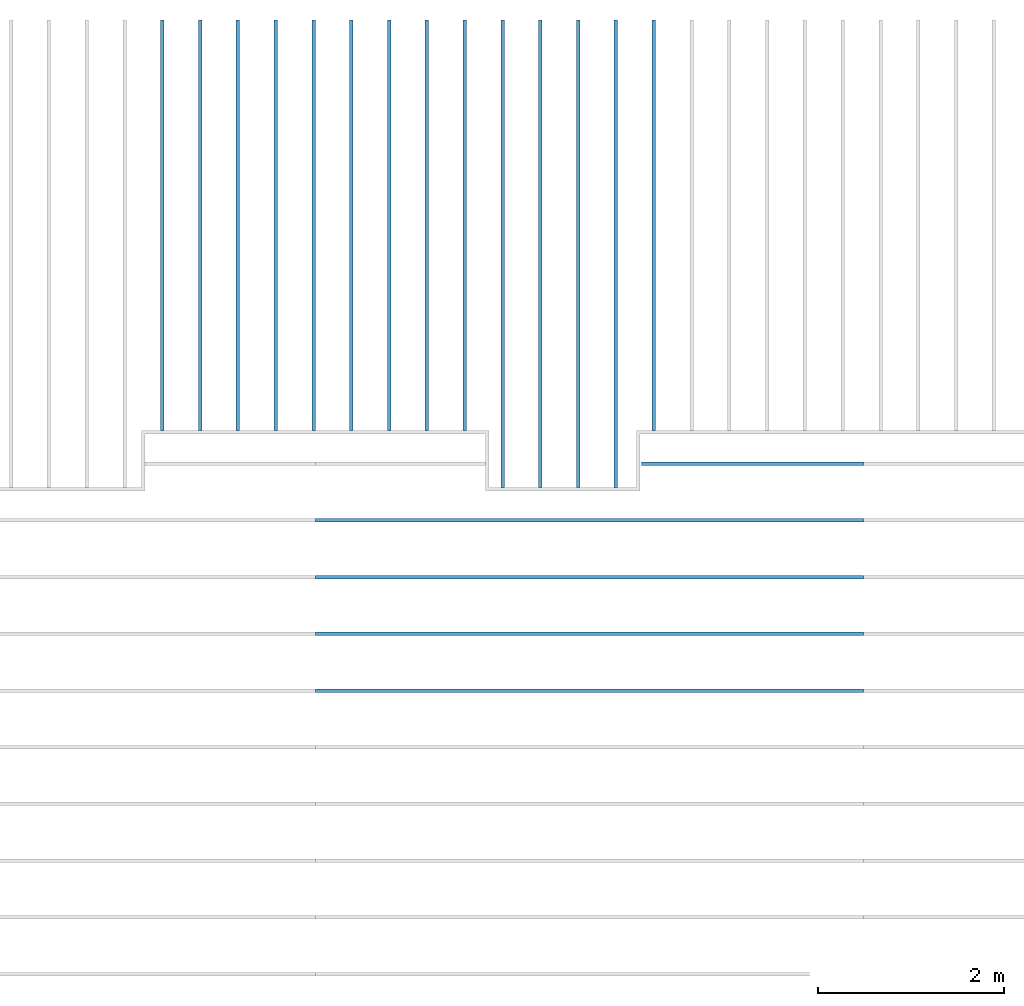
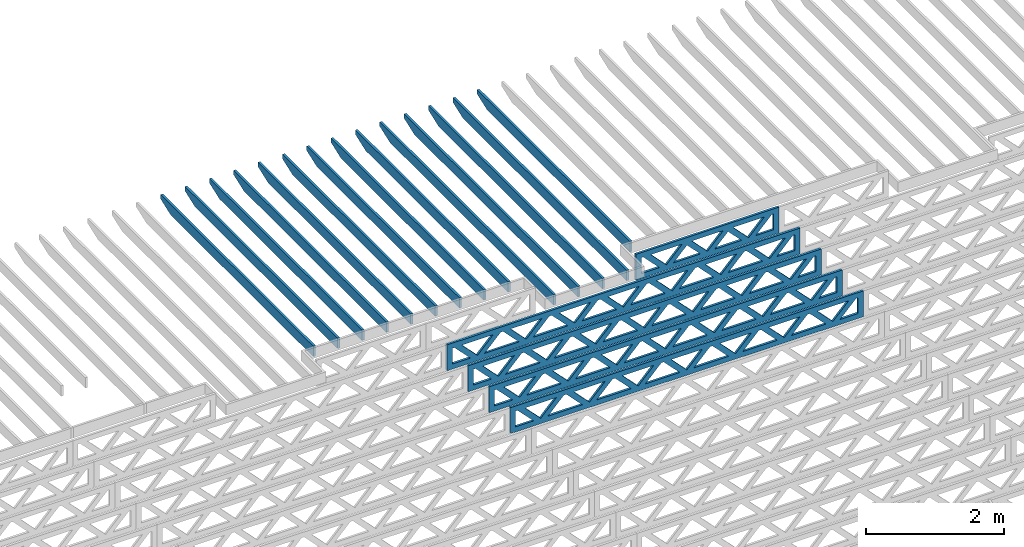
# One storey, part 10 of 17: 19 beams, 2 elements without a shape of their own.
"""IFC4 building model written with IfcOpenShell, lengths in feet."""

from ifc_helpers import new_model, entity, si_unit, converted_unit, derived_unit, direction, frame, frame_2d, origin, origin_2d_with_axis, place, context, subcontext, project, spatial, rectangle, extrude, clip, halfspace, source, transform, mapped, material, material_profile, profile_set, profile_usage, type_object, type_shapes, element, aggregate, save


model = new_model("IFC4")

# Units and contexts
model_context = context("Model", 3, precision=0.0001, world=origin(), true_north=direction((6.12303176911189e-17, 1.0)))
body_context = subcontext(model_context, "Body", "Model", "MODEL_VIEW")
ifc_project = project(units=[converted_unit("LENGTHUNIT", "FOOT", entity("IfcRatioMeasure", 0.3048), si_unit("LENGTHUNIT", "METRE"), dimensions=[1, 0, 0, 0, 0, 0, 0]), converted_unit("AREAUNIT", "SQUARE FOOT", entity("IfcRatioMeasure", 0.09290304), si_unit("AREAUNIT", "SQUARE_METRE"), dimensions=[2, 0, 0, 0, 0, 0, 0]), converted_unit("VOLUMEUNIT", "CUBIC FOOT", entity("IfcRatioMeasure", 0.028316846592), si_unit("VOLUMEUNIT", "CUBIC_METRE"), dimensions=[3, 0, 0, 0, 0, 0, 0]), converted_unit("PLANEANGLEUNIT", "DEGREE", entity("IfcRatioMeasure", 0.0174532925199433), si_unit("PLANEANGLEUNIT", "RADIAN"), dimensions=[0, 0, 0, 0, 0, 0, 0]), si_unit("MASSUNIT", "GRAM", prefix="KILO"), derived_unit("MASSDENSITYUNIT", [(si_unit("MASSUNIT", "GRAM", prefix="KILO"), 1), (si_unit("LENGTHUNIT", "METRE"), -3)]), derived_unit("MOMENTOFINERTIAUNIT", [(si_unit("LENGTHUNIT", "METRE"), 4)]), si_unit("TIMEUNIT", "SECOND"), si_unit("FREQUENCYUNIT", "HERTZ"), si_unit("THERMODYNAMICTEMPERATUREUNIT", "DEGREE_CELSIUS"), derived_unit("THERMALTRANSMITTANCEUNIT", [(si_unit("MASSUNIT", "GRAM", prefix="KILO"), 1), (si_unit("THERMODYNAMICTEMPERATUREUNIT", "KELVIN"), -1), (si_unit("TIMEUNIT", "SECOND"), -3)]), derived_unit("VOLUMETRICFLOWRATEUNIT", [(si_unit("LENGTHUNIT", "METRE"), 3), (si_unit("TIMEUNIT", "SECOND"), -1)]), si_unit("ELECTRICCURRENTUNIT", "AMPERE"), si_unit("ELECTRICVOLTAGEUNIT", "VOLT"), si_unit("POWERUNIT", "WATT"), si_unit("FORCEUNIT", "NEWTON"), si_unit("ILLUMINANCEUNIT", "LUX"), si_unit("LUMINOUSFLUXUNIT", "LUMEN"), si_unit("LUMINOUSINTENSITYUNIT", "CANDELA"), derived_unit("USERDEFINED", [(si_unit("MASSUNIT", "GRAM", prefix="KILO"), -1), (si_unit("LENGTHUNIT", "METRE"), -2), (si_unit("TIMEUNIT", "SECOND"), 3), (si_unit("LUMINOUSFLUXUNIT", "LUMEN"), 1)]), derived_unit("LINEARVELOCITYUNIT", [(si_unit("LENGTHUNIT", "METRE"), 1), (si_unit("TIMEUNIT", "SECOND"), -1)]), si_unit("PRESSUREUNIT", "PASCAL"), derived_unit("USERDEFINED", [(si_unit("LENGTHUNIT", "METRE"), -2), (si_unit("MASSUNIT", "GRAM", prefix="KILO"), 1), (si_unit("TIMEUNIT", "SECOND"), -2)]), derived_unit("LINEARFORCEUNIT", [(si_unit("MASSUNIT", "GRAM", prefix="KILO"), 1), (si_unit("LENGTHUNIT", "METRE"), 1), (si_unit("TIMEUNIT", "SECOND"), -2), (si_unit("LENGTHUNIT", "METRE"), -1)]), derived_unit("PLANARFORCEUNIT", [(si_unit("MASSUNIT", "GRAM", prefix="KILO"), 1), (si_unit("LENGTHUNIT", "METRE"), 1), (si_unit("TIMEUNIT", "SECOND"), -2), (si_unit("LENGTHUNIT", "METRE"), -2)])], contexts=[model_context])

# Site, building, storey
site_placement = place(None, origin())
site = spatial("IfcSite", under=ifc_project, at=site_placement, CompositionType="ELEMENT")
building_placement = place(site_placement, origin())
building = spatial("IfcBuilding", under=site, at=building_placement, CompositionType="ELEMENT")
storey_placement = place(building_placement, frame((0.0, 0.0, 30.4375000000082)))
storey = spatial("IfcBuildingStorey", under=building, at=storey_placement, Name="ROOF", CompositionType="ELEMENT", Elevation=30.4375000000082)

# Assembly, beams
assembly_1_placement = place(storey_placement, origin())
assembly_1 = element("IfcElementAssembly", 1, at=assembly_1_placement, inside=storey, Name="Structural Beam System:Structural Framing System", ObjectType="Structural Beam System:Structural Framing System", AssemblyPlace="NOTDEFINED", PredefinedType="BEAM_GRID")
ifc_material_1 = material(Name="WOOD TRUSS", Category="Materials")
ifc_material_profile_1 = material_profile(ifc_material_1, rectangle(XDim=1.73473973950632, YDim=0.125, at=origin_2d_with_axis()))
ifc_material_profile_2 = material_profile(ifc_material_1, rectangle(XDim=1.73473973950633, YDim=0.125, at=frame_2d((-1.11022302462516e-16, 0.0), x_axis=(1.0, 0.0))))
ifc_material_profile_3 = material_profile(ifc_material_1, rectangle(XDim=1.73473973950632, YDim=0.125, at=origin_2d_with_axis()))
ifc_material_profile_4 = material_profile(ifc_material_1, rectangle(XDim=1.73473973950633, YDim=0.125, at=origin_2d_with_axis()))
ifc_material_profile_5 = material_profile(ifc_material_1, rectangle(XDim=1.73473973950632, YDim=0.125, at=frame_2d((-5.55111512312578e-17, 0.0), x_axis=(1.0, 0.0))))
ifc_material_profile_6 = material_profile(ifc_material_1, rectangle(XDim=1.73473973950633, YDim=0.125, at=frame_2d((-2.77555756156289e-16, 0.0), x_axis=(1.0, 0.0))))
ifc_material_profile_7 = material_profile(ifc_material_1, rectangle(XDim=1.73473973950632, YDim=0.125, at=frame_2d((-4.9960036108132e-16, 0.0), x_axis=(1.0, 0.0))))
ifc_material_profile_8 = material_profile(ifc_material_1, rectangle(XDim=1.73473973950633, YDim=0.125, at=frame_2d((4.44089209850063e-16, 0.0), x_axis=(1.0, 0.0))))
ifc_material_profile_9 = material_profile(ifc_material_1, rectangle(XDim=1.73473973950632, YDim=0.125, at=origin_2d_with_axis()))
ifc_material_profile_10 = material_profile(ifc_material_1, rectangle(XDim=1.73473973950633, YDim=0.125, at=frame_2d((-4.9960036108132e-16, 0.0), x_axis=(1.0, 0.0))))
ifc_material_profile_11 = material_profile(ifc_material_1, rectangle(XDim=0.291666666666664, YDim=0.125, at=frame_2d((-2.77555756156289e-17, 0.0), x_axis=(1.0, 0.0))))
ifc_material_profile_12 = material_profile(ifc_material_1, rectangle(XDim=0.291666666666628, YDim=0.124999999999995, at=frame_2d((-5.55111512312578e-17, 0.0), x_axis=(1.0, 0.0))))
ifc_material_profile_13 = material_profile(ifc_material_1, rectangle(XDim=0.916666666666666, YDim=0.125000000000003, at=frame_2d((-2.77555756156289e-17, 0.0), x_axis=(1.0, 0.0))))
ifc_material_profile_14 = material_profile(ifc_material_1, rectangle(XDim=0.916666666666651, YDim=0.125, at=frame_2d((-2.77555756156289e-17, 0.0), x_axis=(1.0, 0.0))))
ifc_profile_set_1 = profile_set([ifc_material_profile_1, ifc_material_profile_2, ifc_material_profile_3, ifc_material_profile_4, ifc_material_profile_5, ifc_material_profile_6, ifc_material_profile_7, ifc_material_profile_8, ifc_material_profile_9, ifc_material_profile_10, ifc_material_profile_11, ifc_material_profile_12, ifc_material_profile_13, ifc_material_profile_14])
ifc_profile_usage_1 = profile_usage(ifc_profile_set_1, cardinal=8)
beam_type_1 = type_object("IfcBeamType", PredefinedType="BEAM", material=ifc_profile_set_1)
shared_shape_1 = source(origin(), body_context, "Body", "SweptSolid", [
    extrude(rectangle(XDim=1.73473973950632, YDim=0.125, at=origin_2d_with_axis()), frame((0.520059930714934, 0.0, 0.101118361020562), z_axis=(0.720569184836762, 0.0, -0.693383046997606), x_axis=(0.693383046997606, 0.0, 0.720569184836762)), (0.0, 0.0, 1.0), 0.291666666666667),
    extrude(rectangle(XDim=1.73473973950633, YDim=0.125, at=origin_2d_with_axis()), frame((-0.730225942958336, 0.0, -0.101118361020407), z_axis=(0.720569184836758, 0.0, 0.69338304699761), x_axis=(0.69338304699761, 0.0, -0.720569184836758)), (0.0, 0.0, 1.0), 0.291666666666666),
    extrude(rectangle(XDim=1.73473973950632, YDim=0.125, at=origin_2d_with_axis()), frame((2.77005983191593, 0.0, 0.101118361020514), z_axis=(0.720569184836762, 0.0, -0.693383046997606), x_axis=(0.693383046997606, 0.0, 0.720569184836762)), (0.0, 0.0, 1.0), 0.291666666666667),
    extrude(rectangle(XDim=1.73473973950633, YDim=0.125, at=frame_2d((-1.11022302462516e-16, 0.0), x_axis=(1.0, 0.0))), frame((1.51977395824266, 0.0, -0.101118361020455), z_axis=(0.720569184836758, 0.0, 0.69338304699761), x_axis=(0.69338304699761, 0.0, -0.720569184836758)), (0.0, 0.0, 1.0), 0.291666666666666),
    extrude(rectangle(XDim=1.73473973950632, YDim=0.125, at=frame_2d((-5.55111512312578e-17, 0.0), x_axis=(1.0, 0.0))), frame((-1.72993997048606, 0.0, 0.101118361020555), z_axis=(0.720569184836762, 0.0, -0.693383046997606), x_axis=(0.693383046997606, 0.0, 0.720569184836762)), (0.0, 0.0, 1.0), 0.291666666666667),
    extrude(rectangle(XDim=1.73473973950633, YDim=0.125, at=frame_2d((-2.77555756156289e-16, 0.0), x_axis=(1.0, 0.0))), frame((-2.98022584415933, 0.0, -0.101118361020414), z_axis=(0.720569184836758, 0.0, 0.69338304699761), x_axis=(0.69338304699761, 0.0, -0.720569184836758)), (0.0, 0.0, 1.0), 0.291666666666666),
    extrude(rectangle(XDim=0.291666666666664, YDim=0.125, at=frame_2d((-2.77555756156289e-17, 0.0), x_axis=(1.0, 0.0))), frame((-3.91666656786758, 0.0, 0.604166666666611), z_axis=(1.0, 0.0, 0.0), x_axis=(0.0, 0.0, -1.0)), (0.0, 0.0, 1.0), 7.83333313573516),
    extrude(rectangle(XDim=0.291666666666628, YDim=0.124999999999995, at=frame_2d((-5.55111512312578e-17, 0.0), x_axis=(1.0, 0.0))), frame((-3.91666656786737, 0.0, -0.604166666666693), z_axis=(1.0, 0.0, 0.0), x_axis=(0.0, 0.0, -1.0)), (0.0, 0.0, 1.0), 7.83333313573495),
    extrude(rectangle(XDim=0.916666666666666, YDim=0.125000000000003, at=frame_2d((-2.77555756156289e-17, 0.0), x_axis=(1.0, 0.0))), frame((3.62499990120089, 0.0, 0.0), z_axis=(1.0, 0.0, 0.0), x_axis=(0.0, 0.0, -1.0)), (0.0, 0.0, 1.0), 0.291666666666687),
    extrude(rectangle(XDim=0.916666666666651, YDim=0.125, at=frame_2d((-2.77555756156289e-17, 0.0), x_axis=(1.0, 0.0))), frame((-3.91666656786758, 0.0, 0.0), z_axis=(1.0, 0.0, 0.0), x_axis=(0.0, 0.0, -1.0)), (0.0, 0.0, 1.0), 0.291666666666687),
])
type_shapes(beam_type_1, [shared_shape_1])
beam_1_placement = place(assembly_1_placement, frame((-168.321493720097, 957.861934882651, 0.749999999991608), z_axis=(0.0, 0.0, 1.0), x_axis=(-1.0, 0.0, 0.0)))
beam_1 = element("IfcBeam", 2, at=beam_1_placement, type_object=beam_type_1, material=ifc_profile_usage_1, PredefinedType="BEAM", context=body_context, shape_type="MappedRepresentation", body=[
    mapped(shared_shape_1, transform((0.0, 0.0, 0.0), scale=1.0)),
])
ifc_profile_usage_2 = profile_usage(ifc_profile_set_1, cardinal=8)
beam_type_2 = type_object("IfcBeamType", PredefinedType="BEAM", material=ifc_profile_set_1)
shared_shape_2 = source(origin(), body_context, "Body", "SweptSolid", [
    extrude(rectangle(XDim=1.73473973950632, YDim=0.125, at=frame_2d((-5.55111512312578e-16, 0.0), x_axis=(1.0, 0.0))), frame((5.85339326404794, 0.0, 0.101118361020562), z_axis=(0.720569184836762, 0.0, -0.693383046997606), x_axis=(0.693383046997606, 0.0, 0.720569184836762)), (0.0, 0.0, 1.0), 0.291666666666667),
    extrude(rectangle(XDim=1.73473973950633, YDim=0.125, at=frame_2d((-4.9960036108132e-16, 0.0), x_axis=(1.0, 0.0))), frame((4.60310739037467, 0.0, -0.101118361020407), z_axis=(0.720569184836758, 0.0, 0.69338304699761), x_axis=(0.69338304699761, 0.0, -0.720569184836758)), (0.0, 0.0, 1.0), 0.291666666666667),
    extrude(rectangle(XDim=1.73473973950632, YDim=0.125, at=frame_2d((3.33066907387547e-16, 0.0), x_axis=(1.0, 0.0))), frame((3.18672659738144, 0.0, 0.101118361020562), z_axis=(0.720569184836762, 0.0, -0.693383046997606), x_axis=(0.693383046997606, 0.0, 0.720569184836762)), (0.0, 0.0, 1.0), 0.291666666666667),
    extrude(rectangle(XDim=1.73473973950633, YDim=0.125, at=frame_2d((-1.11022302462516e-16, 0.0), x_axis=(1.0, 0.0))), frame((1.93644072370817, 0.0, -0.101118361020407), z_axis=(0.720569184836758, 0.0, 0.69338304699761), x_axis=(0.69338304699761, 0.0, -0.720569184836758)), (0.0, 0.0, 1.0), 0.291666666666666),
    extrude(rectangle(XDim=1.73473973950632, YDim=0.125, at=frame_2d((5.55111512312578e-17, 0.0), x_axis=(1.0, 0.0))), frame((0.520059930714937, 0.0, 0.101118361020562), z_axis=(0.720569184836762, 0.0, -0.693383046997606), x_axis=(0.693383046997606, 0.0, 0.720569184836762)), (0.0, 0.0, 1.0), 0.291666666666667),
    extrude(rectangle(XDim=1.73473973950633, YDim=0.125, at=origin_2d_with_axis()), frame((-0.730225942958334, 0.0, -0.101118361020407), z_axis=(0.720569184836758, 0.0, 0.69338304699761), x_axis=(0.69338304699761, 0.0, -0.720569184836758)), (0.0, 0.0, 1.0), 0.291666666666666),
    extrude(rectangle(XDim=1.73473973950632, YDim=0.125, at=frame_2d((-5.55111512312578e-17, 0.0), x_axis=(1.0, 0.0))), frame((-2.14660673595157, 0.0, 0.101118361020562), z_axis=(0.720569184836762, 0.0, -0.693383046997606), x_axis=(0.693383046997606, 0.0, 0.720569184836762)), (0.0, 0.0, 1.0), 0.291666666666667),
    extrude(rectangle(XDim=1.73473973950633, YDim=0.125, at=frame_2d((-2.77555756156289e-16, 0.0), x_axis=(1.0, 0.0))), frame((-3.39689260962484, 0.0, -0.101118361020407), z_axis=(0.720569184836758, 0.0, 0.69338304699761), x_axis=(0.69338304699761, 0.0, -0.720569184836758)), (0.0, 0.0, 1.0), 0.291666666666666),
    extrude(rectangle(XDim=1.73473973950632, YDim=0.125, at=origin_2d_with_axis()), frame((-4.81327340261807, 0.0, 0.101118361020562), z_axis=(0.720569184836762, 0.0, -0.693383046997606), x_axis=(0.693383046997606, 0.0, 0.720569184836762)), (0.0, 0.0, 1.0), 0.291666666666667),
    extrude(rectangle(XDim=1.73473973950633, YDim=0.125, at=frame_2d((-4.9960036108132e-16, 0.0), x_axis=(1.0, 0.0))), frame((-6.06355927629134, 0.0, -0.101118361020407), z_axis=(0.720569184836758, 0.0, 0.69338304699761), x_axis=(0.69338304699761, 0.0, -0.720569184836758)), (0.0, 0.0, 1.0), 0.291666666666667),
    extrude(rectangle(XDim=1.73473973950632, YDim=0.125, at=frame_2d((-1.0547118733939e-15, 0.0), x_axis=(1.0, 0.0))), frame((8.52005993071445, 0.0, 0.101118361020506), z_axis=(0.720569184836761, 0.0, -0.693383046997607), x_axis=(0.693383046997607, 0.0, 0.720569184836761)), (0.0, 0.0, 1.0), 0.291666666666667),
    extrude(rectangle(XDim=1.73473973950633, YDim=0.125, at=origin_2d_with_axis()), frame((7.26977405704118, 0.0, -0.101118361020463), z_axis=(0.720569184836758, 0.0, 0.69338304699761), x_axis=(0.69338304699761, 0.0, -0.720569184836758)), (0.0, 0.0, 1.0), 0.291666666666667),
    extrude(rectangle(XDim=1.73473973950632, YDim=0.125, at=frame_2d((4.44089209850063e-16, 0.0), x_axis=(1.0, 0.0))), frame((-7.47994006928457, 0.0, 0.101118361020561), z_axis=(0.720569184836762, 0.0, -0.693383046997606), x_axis=(0.693383046997606, 0.0, 0.720569184836762)), (0.0, 0.0, 1.0), 0.291666666666666),
    extrude(rectangle(XDim=1.73473973950633, YDim=0.125, at=origin_2d_with_axis()), frame((-8.73022594295784, 0.0, -0.101118361020408), z_axis=(0.720569184836758, 0.0, 0.69338304699761), x_axis=(0.69338304699761, 0.0, -0.720569184836758)), (0.0, 0.0, 1.0), 0.291666666666666),
    extrude(rectangle(XDim=0.291666666666664, YDim=0.125, at=frame_2d((-2.77555756156289e-17, 0.0), x_axis=(1.0, 0.0))), frame((-9.66666666666609, 0.0, 0.604166666666611), z_axis=(1.0, 0.0, 0.0), x_axis=(0.0, 0.0, -1.0)), (0.0, 0.0, 1.0), 19.3333333333322),
    extrude(rectangle(XDim=0.291666666666628, YDim=0.124999999999995, at=frame_2d((-5.55111512312578e-17, 0.0), x_axis=(1.0, 0.0))), frame((-9.66666666666588, 0.0, -0.604166666666693), z_axis=(1.0, 0.0, 0.0), x_axis=(0.0, 0.0, -1.0)), (0.0, 0.0, 1.0), 19.333333333332),
    extrude(rectangle(XDim=0.916666666666666, YDim=0.125000000000003, at=frame_2d((-2.77555756156289e-17, 0.0), x_axis=(1.0, 0.0))), frame((9.3749999999994, 0.0, 0.0), z_axis=(1.0, 0.0, 0.0), x_axis=(0.0, 0.0, -1.0)), (0.0, 0.0, 1.0), 0.291666666666687),
    extrude(rectangle(XDim=0.916666666666651, YDim=0.125, at=frame_2d((-2.77555756156289e-17, 0.0), x_axis=(1.0, 0.0))), frame((-9.66666666666609, 0.0, 0.0), z_axis=(1.0, 0.0, 0.0), x_axis=(0.0, 0.0, -1.0)), (0.0, 0.0, 1.0), 0.291666666666687),
])
type_shapes(beam_type_2, [shared_shape_2])
beam_2_placement = place(assembly_1_placement, frame((-174.071493818896, 955.861934882651, 0.749999999991608), z_axis=(0.0, 0.0, 1.0), x_axis=(-1.0, 0.0, 0.0)))
beam_2 = element("IfcBeam", 3, at=beam_2_placement, type_object=beam_type_2, material=ifc_profile_usage_2, PredefinedType="BEAM", context=body_context, shape_type="MappedRepresentation", body=[
    mapped(shared_shape_2, transform((0.0, 0.0, 0.0), scale=1.0)),
])
ifc_profile_usage_3 = profile_usage(ifc_profile_set_1, cardinal=8)
beam_3_placement = place(assembly_1_placement, frame((-174.071493818896, 953.861934882651, 0.749999999991616), z_axis=(0.0, 0.0, 1.0), x_axis=(-1.0, 0.0, 0.0)))
beam_3 = element("IfcBeam", 4, at=beam_3_placement, type_object=beam_type_2, material=ifc_profile_usage_3, PredefinedType="BEAM", context=body_context, shape_type="MappedRepresentation", body=[
    mapped(shared_shape_2, transform((0.0, 0.0, 0.0), scale=1.0)),
])
ifc_profile_usage_4 = profile_usage(ifc_profile_set_1, cardinal=8)
beam_4_placement = place(assembly_1_placement, frame((-174.071493818896, 951.861934882651, 0.749999999991623), z_axis=(0.0, 0.0, 1.0), x_axis=(-1.0, 0.0, 0.0)))
beam_4 = element("IfcBeam", 5, at=beam_4_placement, type_object=beam_type_2, material=ifc_profile_usage_4, PredefinedType="BEAM", context=body_context, shape_type="MappedRepresentation", body=[
    mapped(shared_shape_2, transform((0.0, 0.0, 0.0), scale=1.0)),
])
ifc_profile_usage_5 = profile_usage(ifc_profile_set_1, cardinal=8)
beam_5_placement = place(assembly_1_placement, frame((-174.071493818896, 949.861934882651, 0.749999999991623), z_axis=(0.0, 0.0, 1.0), x_axis=(-1.0, 0.0, 0.0)))
beam_5 = element("IfcBeam", 6, at=beam_5_placement, type_object=beam_type_2, material=ifc_profile_usage_5, PredefinedType="BEAM", context=body_context, shape_type="MappedRepresentation", body=[
    mapped(shared_shape_2, transform((0.0, 0.0, 0.0), scale=1.0)),
])
aggregate(assembly_1, [beam_1, beam_2, beam_3, beam_4, beam_5])

assembly_2_placement = place(storey_placement, origin())
assembly_2 = element("IfcElementAssembly", 7, at=assembly_2_placement, inside=storey, Name="Structural Beam System:Structural Framing System", ObjectType="Structural Beam System:Structural Framing System", AssemblyPlace="NOTDEFINED", PredefinedType="BEAM_GRID")
ifc_material_2 = material(Name="2X ROOF JOISTS - EXT. STAIN-1 - SEE LIFE SAFETY", Category="Materials")
ifc_material_profile_15 = material_profile(ifc_material_2, rectangle(XDim=0.604166666666667, YDim=0.125000000000011, at=frame_2d((0.0, 0.0), x_axis=(0.0, 1.0))))
ifc_profile_set_2 = profile_set([ifc_material_profile_15])
ifc_profile_usage_6 = profile_usage(ifc_profile_set_2, cardinal=8)
beam_type_3 = type_object("IfcBeamType", PredefinedType="BEAM", material=ifc_profile_set_2)
shared_shape_3 = source(origin(), body_context, "Body", "Clipping", [
    clip(extrude(rectangle(XDim=0.604166666666667, YDim=0.125000000000011, at=frame_2d((0.0, 0.0), x_axis=(0.0, 1.0))), frame((-8.24296473987818, 0.0, 0.0), z_axis=(1.0, 0.0, 0.0), x_axis=(0.0, 1.0, 0.0)), (0.0, 0.0, 1.0), 16.4859294797564), halfspace(frame((-7.26989982048795, -0.0625000000000026, -0.30208333333334), z_axis=(-0.34202014332567, 0.0, -0.939692620785908), x_axis=(0.0, 1.0, 0.0)), False)),
])
type_shapes(beam_type_3, [shared_shape_3])
beam_6_placement = place(assembly_2_placement, frame((-173.133993818795, 965.271566289195, 1.07291666665816), z_axis=(0.0, 0.0, 1.0), x_axis=(0.0, -1.0, 0.0)))
beam_6 = element("IfcBeam", 8, at=beam_6_placement, type_object=beam_type_3, material=ifc_profile_usage_6, PredefinedType="BEAM", context=body_context, shape_type="MappedRepresentation", body=[
    mapped(shared_shape_3, transform((0.0, 0.0, 0.0), scale=1.0)),
])
ifc_profile_usage_7 = profile_usage(ifc_profile_set_2, cardinal=8)
beam_7_placement = place(assembly_2_placement, frame((-174.467327152128, 965.271566289195, 1.07291666665817), z_axis=(0.0, 0.0, 1.0), x_axis=(0.0, -1.0, 0.0)))
beam_7 = element("IfcBeam", 9, at=beam_7_placement, type_object=beam_type_3, material=ifc_profile_usage_7, PredefinedType="BEAM", context=body_context, shape_type="MappedRepresentation", body=[
    mapped(shared_shape_3, transform((0.0, 0.0, 0.0), scale=1.0)),
])
ifc_profile_usage_8 = profile_usage(ifc_profile_set_2, cardinal=8)
beam_8_placement = place(assembly_2_placement, frame((-175.800660485462, 965.271566289195, 1.07291666665817), z_axis=(0.0, 0.0, 1.0), x_axis=(0.0, -1.0, 0.0)))
beam_8 = element("IfcBeam", 10, at=beam_8_placement, type_object=beam_type_3, material=ifc_profile_usage_8, PredefinedType="BEAM", context=body_context, shape_type="MappedRepresentation", body=[
    mapped(shared_shape_3, transform((0.0, 0.0, 0.0), scale=1.0)),
])
ifc_profile_usage_9 = profile_usage(ifc_profile_set_2, cardinal=8)
beam_9_placement = place(assembly_2_placement, frame((-177.133993818795, 965.271566289195, 1.07291666665818), z_axis=(0.0, 0.0, 1.0), x_axis=(0.0, -1.0, 0.0)))
beam_9 = element("IfcBeam", 11, at=beam_9_placement, type_object=beam_type_3, material=ifc_profile_usage_9, PredefinedType="BEAM", context=body_context, shape_type="MappedRepresentation", body=[
    mapped(shared_shape_3, transform((0.0, 0.0, 0.0), scale=1.0)),
])
ifc_profile_usage_10 = profile_usage(ifc_profile_set_2, cardinal=8)
beam_type_4 = type_object("IfcBeamType", PredefinedType="BEAM", material=ifc_profile_set_2)
shared_shape_4 = source(origin(), body_context, "Body", "Clipping", [
    clip(extrude(rectangle(XDim=0.604166666666667, YDim=0.125000000000011, at=frame_2d((0.0, 0.0), x_axis=(0.0, 1.0))), frame((-7.24296361464559, 0.0, 0.0), z_axis=(1.0, 0.0, 0.0), x_axis=(0.0, 1.0, 0.0)), (0.0, 0.0, 1.0), 14.4859272292912), halfspace(frame((-6.26989869525536, -0.0625000000000026, -0.30208333333334), z_axis=(-0.34202014332567, 0.0, -0.939692620785908), x_axis=(0.0, 1.0, 0.0)), False)),
])
type_shapes(beam_type_4, [shared_shape_4])
beam_10_placement = place(assembly_2_placement, frame((-182.467327152128, 966.271567408338, 1.0729166666583), z_axis=(0.0, 0.0, 1.0), x_axis=(0.0, -1.0, 0.0)))
beam_10 = element("IfcBeam", 12, at=beam_10_placement, type_object=beam_type_4, material=ifc_profile_usage_10, PredefinedType="BEAM", context=body_context, shape_type="MappedRepresentation", body=[
    mapped(shared_shape_4, transform((0.0, 0.0, 0.0), scale=1.0)),
])
ifc_profile_usage_11 = profile_usage(ifc_profile_set_2, cardinal=8)
beam_type_5 = type_object("IfcBeamType", PredefinedType="BEAM", material=ifc_profile_set_2)
shared_shape_5 = source(origin(), body_context, "Body", "Clipping", [
    clip(extrude(rectangle(XDim=0.604166666666667, YDim=0.125000000000011, at=frame_2d((0.0, 0.0), x_axis=(0.0, 1.0))), frame((-7.24296378214677, 0.0, 0.0), z_axis=(1.0, 0.0, 0.0), x_axis=(0.0, 1.0, 0.0)), (0.0, 0.0, 1.0), 14.4859275642935), halfspace(frame((-6.26989886275655, -0.0625000000000026, -0.30208333333334), z_axis=(-0.34202014332567, 0.0, -0.939692620785908), x_axis=(0.0, 1.0, 0.0)), False)),
])
type_shapes(beam_type_5, [shared_shape_5])
beam_11_placement = place(assembly_2_placement, frame((-183.800660485462, 966.271567258244, 1.0729166666583), z_axis=(0.0, 0.0, 1.0), x_axis=(0.0, -1.0, 0.0)))
beam_11 = element("IfcBeam", 13, at=beam_11_placement, type_object=beam_type_5, material=ifc_profile_usage_11, PredefinedType="BEAM", context=body_context, shape_type="MappedRepresentation", body=[
    mapped(shared_shape_5, transform((0.0, 0.0, 0.0), scale=1.0)),
])
ifc_profile_usage_12 = profile_usage(ifc_profile_set_2, cardinal=8)
beam_type_6 = type_object("IfcBeamType", PredefinedType="BEAM", material=ifc_profile_set_2)
shared_shape_6 = source(origin(), body_context, "Body", "Clipping", [
    clip(extrude(rectangle(XDim=0.604166666666667, YDim=0.125000000000011, at=frame_2d((0.0, 0.0), x_axis=(0.0, 1.0))), frame((-7.24296512215625, 0.0, 0.0), z_axis=(1.0, 0.0, 0.0), x_axis=(0.0, 1.0, 0.0)), (0.0, 0.0, 1.0), 14.4859302443125), halfspace(frame((-6.26990020276602, -0.0625000000000026, -0.30208333333334), z_axis=(-0.34202014332567, 0.0, -0.939692620785908), x_axis=(0.0, 1.0, 0.0)), False)),
])
type_shapes(beam_type_6, [shared_shape_6])
beam_12_placement = place(assembly_2_placement, frame((-171.800660485462, 966.271565906917, 1.07291666665829), z_axis=(0.0, 0.0, 1.0), x_axis=(0.0, -1.0, 0.0)))
beam_12 = element("IfcBeam", 14, at=beam_12_placement, type_object=beam_type_6, material=ifc_profile_usage_12, PredefinedType="BEAM", context=body_context, shape_type="MappedRepresentation", body=[
    mapped(shared_shape_6, transform((0.0, 0.0, 0.0), scale=1.0)),
])
ifc_profile_usage_13 = profile_usage(ifc_profile_set_2, cardinal=8)
beam_type_7 = type_object("IfcBeamType", PredefinedType="BEAM", material=ifc_profile_set_2)
shared_shape_7 = source(origin(), body_context, "Body", "Clipping", [
    clip(extrude(rectangle(XDim=0.604166666666667, YDim=0.125000000000011, at=frame_2d((0.0, 0.0), x_axis=(0.0, 1.0))), frame((-7.24296317045162, 0.0, 0.0), z_axis=(1.0, 0.0, 0.0), x_axis=(0.0, 1.0, 0.0)), (0.0, 0.0, 1.0), 14.4859263409032), halfspace(frame((-6.26989825106139, -0.0625000000000026, -0.30208333333334), z_axis=(-0.34202014332567, 0.0, -0.939692620785908), x_axis=(0.0, 1.0, 0.0)), False)),
])
type_shapes(beam_type_7, [shared_shape_7])
beam_13_placement = place(assembly_2_placement, frame((-178.467327152128, 966.271567858622, 1.07291666665829), z_axis=(0.0, 0.0, 1.0), x_axis=(0.0, -1.0, 0.0)))
beam_13 = element("IfcBeam", 15, at=beam_13_placement, type_object=beam_type_7, material=ifc_profile_usage_13, PredefinedType="BEAM", context=body_context, shape_type="MappedRepresentation", body=[
    mapped(shared_shape_7, transform((0.0, 0.0, 0.0), scale=1.0)),
])
ifc_profile_usage_14 = profile_usage(ifc_profile_set_2, cardinal=8)
beam_type_8 = type_object("IfcBeamType", PredefinedType="BEAM", material=ifc_profile_set_2)
shared_shape_8 = source(origin(), body_context, "Body", "Clipping", [
    clip(extrude(rectangle(XDim=0.604166666666667, YDim=0.125000000000011, at=frame_2d((0.0, 0.0), x_axis=(0.0, 1.0))), frame((-7.24296332054621, 0.0, 0.0), z_axis=(1.0, 0.0, 0.0), x_axis=(0.0, 1.0, 0.0)), (0.0, 0.0, 1.0), 14.4859266410924), halfspace(frame((-6.26989840115598, -0.0625000000000026, -0.30208333333334), z_axis=(-0.34202014332567, 0.0, -0.939692620785908), x_axis=(0.0, 1.0, 0.0)), False)),
])
type_shapes(beam_type_8, [shared_shape_8])
beam_14_placement = place(assembly_2_placement, frame((-179.800660485462, 966.271567708527, 1.07291666665829), z_axis=(0.0, 0.0, 1.0), x_axis=(0.0, -1.0, 0.0)))
beam_14 = element("IfcBeam", 16, at=beam_14_placement, type_object=beam_type_8, material=ifc_profile_usage_14, PredefinedType="BEAM", context=body_context, shape_type="MappedRepresentation", body=[
    mapped(shared_shape_8, transform((0.0, 0.0, 0.0), scale=1.0)),
])
ifc_profile_usage_15 = profile_usage(ifc_profile_set_2, cardinal=8)
beam_type_9 = type_object("IfcBeamType", PredefinedType="BEAM", material=ifc_profile_set_2)
shared_shape_9 = source(origin(), body_context, "Body", "Clipping", [
    clip(extrude(rectangle(XDim=0.604166666666667, YDim=0.125000000000011, at=frame_2d((0.0, -5.55111512312578e-17), x_axis=(0.0, 1.0))), frame((-7.24296347064075, 0.0, 0.0), z_axis=(1.0, 0.0, 0.0), x_axis=(0.0, 1.0, 0.0)), (0.0, 0.0, 1.0), 14.4859269412815), halfspace(frame((-6.26989855125052, -0.0625000000000026, -0.30208333333334), z_axis=(-0.34202014332567, 0.0, -0.939692620785908), x_axis=(0.0, 1.0, 0.0)), False)),
])
type_shapes(beam_type_9, [shared_shape_9])
beam_15_placement = place(assembly_2_placement, frame((-181.133993818795, 966.271567558433, 1.07291666665829), z_axis=(0.0, 0.0, 1.0), x_axis=(0.0, -1.0, 0.0)))
beam_15 = element("IfcBeam", 17, at=beam_15_placement, type_object=beam_type_9, material=ifc_profile_usage_15, PredefinedType="BEAM", context=body_context, shape_type="MappedRepresentation", body=[
    mapped(shared_shape_9, transform((0.0, 0.0, 0.0), scale=1.0)),
])
ifc_profile_usage_16 = profile_usage(ifc_profile_set_2, cardinal=8)
beam_type_10 = type_object("IfcBeamType", PredefinedType="BEAM", material=ifc_profile_set_2)
shared_shape_10 = source(origin(), body_context, "Body", "Clipping", [
    clip(extrude(rectangle(XDim=0.604166666666667, YDim=0.125000000000011, at=frame_2d((0.0, 0.0), x_axis=(0.0, 1.0))), frame((-7.24296392092435, 0.0, 0.0), z_axis=(1.0, 0.0, 0.0), x_axis=(0.0, 1.0, 0.0)), (0.0, 0.0, 1.0), 14.4859278418487), halfspace(frame((-6.26989900153413, -0.0625000000000026, -0.30208333333334), z_axis=(-0.34202014332567, 0.0, -0.939692620785908), x_axis=(0.0, 1.0, 0.0)), False)),
])
type_shapes(beam_type_10, [shared_shape_10])
beam_16_placement = place(assembly_2_placement, frame((-185.133993818795, 966.271567108149, 1.0729166666583), z_axis=(0.0, 0.0, 1.0), x_axis=(0.0, -1.0, 0.0)))
beam_16 = element("IfcBeam", 18, at=beam_16_placement, type_object=beam_type_10, material=ifc_profile_usage_16, PredefinedType="BEAM", context=body_context, shape_type="MappedRepresentation", body=[
    mapped(shared_shape_10, transform((0.0, 0.0, 0.0), scale=1.0)),
])
ifc_profile_usage_17 = profile_usage(ifc_profile_set_2, cardinal=8)
beam_type_11 = type_object("IfcBeamType", PredefinedType="BEAM", material=ifc_profile_set_2)
shared_shape_11 = source(origin(), body_context, "Body", "Clipping", [
    clip(extrude(rectangle(XDim=0.604166666666667, YDim=0.125000000000011, at=frame_2d((0.0, 0.0), x_axis=(0.0, 1.0))), frame((-7.24296407101895, 0.0, 0.0), z_axis=(1.0, 0.0, 0.0), x_axis=(0.0, 1.0, 0.0)), (0.0, 0.0, 1.0), 14.4859281420379), halfspace(frame((-6.26989915162872, -0.0625000000000026, -0.30208333333334), z_axis=(-0.34202014332567, 0.0, -0.939692620785908), x_axis=(0.0, 1.0, 0.0)), False)),
])
type_shapes(beam_type_11, [shared_shape_11])
beam_17_placement = place(assembly_2_placement, frame((-186.467327152128, 966.271566958054, 1.0729166666583), z_axis=(0.0, 0.0, 1.0), x_axis=(0.0, -1.0, 0.0)))
beam_17 = element("IfcBeam", 19, at=beam_17_placement, type_object=beam_type_11, material=ifc_profile_usage_17, PredefinedType="BEAM", context=body_context, shape_type="MappedRepresentation", body=[
    mapped(shared_shape_11, transform((0.0, 0.0, 0.0), scale=1.0)),
])
ifc_profile_usage_18 = profile_usage(ifc_profile_set_2, cardinal=8)
beam_type_12 = type_object("IfcBeamType", PredefinedType="BEAM", material=ifc_profile_set_2)
shared_shape_12 = source(origin(), body_context, "Body", "Clipping", [
    clip(extrude(rectangle(XDim=0.604166666666667, YDim=0.125000000000011, at=frame_2d((0.0, 0.0), x_axis=(0.0, 1.0))), frame((-7.24296422111348, 0.0, 0.0), z_axis=(1.0, 0.0, 0.0), x_axis=(0.0, 1.0, 0.0)), (0.0, 0.0, 1.0), 14.485928442227), halfspace(frame((-6.26989930172326, -0.0625000000000026, -0.30208333333334), z_axis=(-0.34202014332567, 0.0, -0.939692620785908), x_axis=(0.0, 1.0, 0.0)), False)),
])
type_shapes(beam_type_12, [shared_shape_12])
beam_18_placement = place(assembly_2_placement, frame((-187.800660485462, 966.27156680796, 1.0729166666583), z_axis=(0.0, 0.0, 1.0), x_axis=(0.0, -1.0, 0.0)))
beam_18 = element("IfcBeam", 20, at=beam_18_placement, type_object=beam_type_12, material=ifc_profile_usage_18, PredefinedType="BEAM", context=body_context, shape_type="MappedRepresentation", body=[
    mapped(shared_shape_12, transform((0.0, 0.0, 0.0), scale=1.0)),
])
ifc_profile_usage_19 = profile_usage(ifc_profile_set_2, cardinal=8)
beam_type_13 = type_object("IfcBeamType", PredefinedType="BEAM", material=ifc_profile_set_2)
shared_shape_13 = source(origin(), body_context, "Body", "Clipping", [
    clip(extrude(rectangle(XDim=0.604166666666667, YDim=0.125000000000011, at=frame_2d((0.0, 0.0), x_axis=(0.0, 1.0))), frame((-7.24296437120802, 0.0, 0.0), z_axis=(1.0, 0.0, 0.0), x_axis=(0.0, 1.0, 0.0)), (0.0, 0.0, 1.0), 14.485928742416), halfspace(frame((-6.26989945181779, -0.0625000000000026, -0.30208333333334), z_axis=(-0.34202014332567, 0.0, -0.939692620785908), x_axis=(0.0, 1.0, 0.0)), False)),
])
type_shapes(beam_type_13, [shared_shape_13])
beam_19_placement = place(assembly_2_placement, frame((-189.133993818795, 966.271566657865, 1.0729166666583), z_axis=(0.0, 0.0, 1.0), x_axis=(0.0, -1.0, 0.0)))
beam_19 = element("IfcBeam", 21, at=beam_19_placement, type_object=beam_type_13, material=ifc_profile_usage_19, PredefinedType="BEAM", context=body_context, shape_type="MappedRepresentation", body=[
    mapped(shared_shape_13, transform((0.0, 0.0, 0.0), scale=1.0)),
])
aggregate(assembly_2, [beam_12, beam_6, beam_7, beam_8, beam_9, beam_13, beam_14, beam_15, beam_10, beam_11, beam_16, beam_17, beam_18, beam_19])

save(model, "model.ifc")
